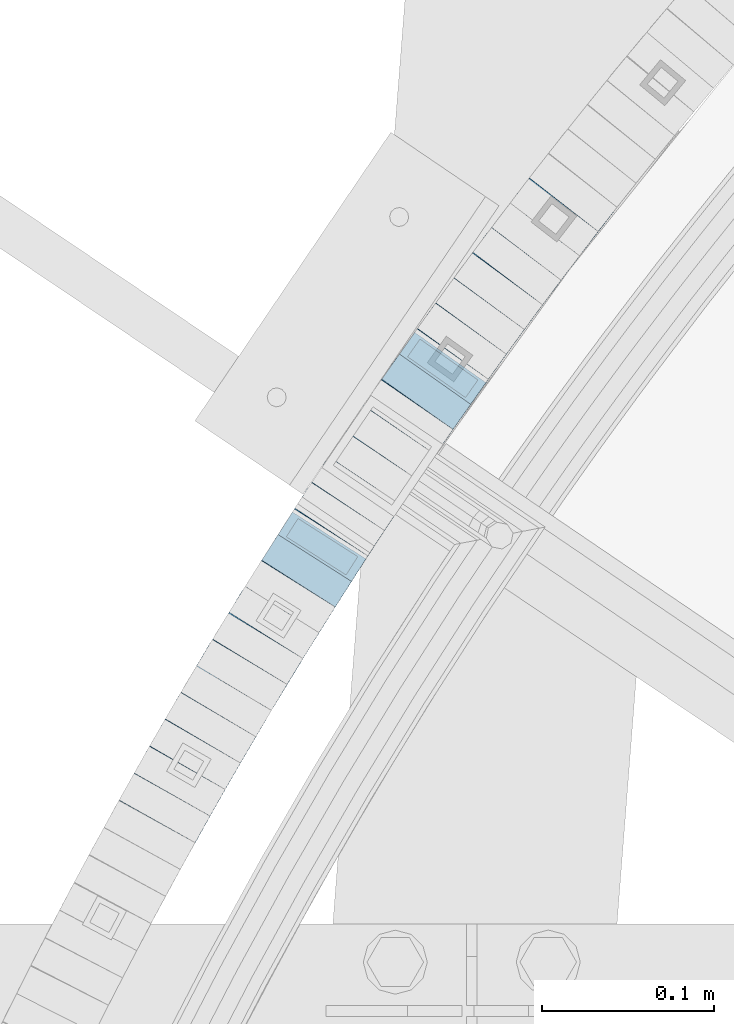
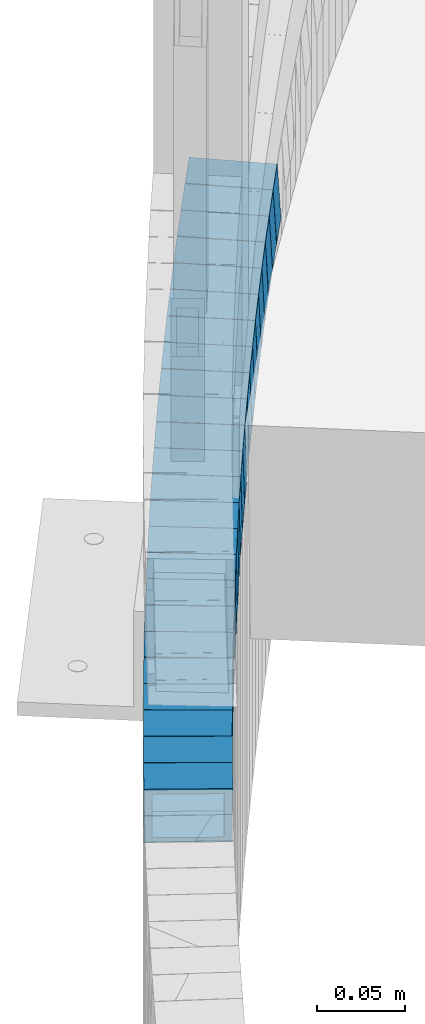
# One storey, part 738 of 975: 24 beams.
"""IFC2X3 building model written with IfcOpenShell, lengths in millimetres."""

from ifc_helpers import new_model, si_unit, frame, origin_with_axes, place, context, subcontext, project, spatial, faceted_brep, material, type_object, element, save


model = new_model("IFC2X3")

# Units and contexts
model_context = context("Model", 3, precision=1e-05, world=origin_with_axes())
body_context = subcontext(model_context, "Body", "Model", "MODEL_VIEW")
ifc_project = project(units=[si_unit("LENGTHUNIT", "METRE", prefix="MILLI"), si_unit("AREAUNIT", "SQUARE_METRE"), si_unit("VOLUMEUNIT", "CUBIC_METRE"), si_unit("MASSUNIT", "GRAM", prefix="KILO"), si_unit("TIMEUNIT", "SECOND"), si_unit("PLANEANGLEUNIT", "RADIAN"), si_unit("SOLIDANGLEUNIT", "STERADIAN"), si_unit("THERMODYNAMICTEMPERATUREUNIT", "DEGREE_CELSIUS"), si_unit("LUMINOUSINTENSITYUNIT", "LUMEN")], contexts=[model_context])

# Site, building, storey
site_placement = place(None, origin_with_axes())
site = spatial("IfcSite", under=ifc_project, at=site_placement, CompositionType="ELEMENT")
building_placement = place(site_placement, origin_with_axes())
building = spatial("IfcBuilding", under=site, at=building_placement, Name="Undefined", CompositionType="ELEMENT")
storey_placement = place(building_placement, origin_with_axes())
storey = spatial("IfcBuildingStorey", under=building, at=storey_placement, Name="Undefined", CompositionType="ELEMENT", Elevation=0.0)

# Beams
ifc_material = material()
beam_type = type_object("IfcBeamType", Name="HSS2X2X.188_TUBES", PredefinedType="NOTDEFINED")
beam_1_placement = place(storey_placement, frame((32470.512431481, 5168.51406782556, 211.007242107061), z_axis=(0.791161585042768, -0.611607183045306, -3.09927372654783e-12), x_axis=(-0.582537973064696, -0.753558295083626, -0.3046299490338)))
element("IfcBeam", 1, at=beam_1_placement, inside=storey, type_object=beam_type, material=ifc_material, Name="WALL", ObjectType="HSS2X2X.188_TUBES", context=body_context, shape_type="Brep", body=[
    faceted_brep([(0.0, 20.6374999999753, -20.6375000000298), (0.0, -20.6375000000153, -20.6375000000153), (18.7112265765609, -20.6375000000062, -20.6374999999862), (18.7112265765645, 20.6374999999898, -20.6374999999789), (0.0, -20.6374999999825, 20.6375000000335), (18.7112265765209, -20.6374999999916, 20.6374999999607), (0.0, 20.6375000000116, 20.6375000000189), (18.7112265765245, 20.6375000000025, 20.6374999999716), (0.0, 25.3999999999724, -25.4000000000342), (0.0, 25.400000000016, 25.4000000000196), (18.7112265765172, 25.4000000000051, 25.3999999999614), (18.7112265765718, 25.3999999999887, -25.3999999999724), (0.0, -25.399999999976, 25.4000000000378), (18.7112265765136, -25.3999999999905, 25.3999999999542), (0.0, -25.400000000016, -25.4000000000196), (18.7112265765682, -25.4000000000069, -25.3999999999796)], [[[0, 1, 2, 3]], [[1, 4, 5, 2]], [[4, 6, 7, 5]], [[6, 0, 3, 7]], [[8, 9, 10, 11]], [[9, 12, 13, 10]], [[12, 14, 15, 13]], [[14, 8, 11, 15]], [[13, 15, 11, 10], [5, 7, 3, 2]], [[14, 12, 9, 8], [6, 4, 1, 0]]]),
])
beam_2_placement = place(storey_placement, frame((32459.4205086382, 5154.30692939824, 205.334225868715), z_axis=(0.797986598681653, -0.602675193055502, -7.64323999646878e-11), x_axis=(-0.573390259939947, -0.759211177920499, -0.307931805967765)))
element("IfcBeam", 2, at=beam_2_placement, inside=storey, type_object=beam_type, material=ifc_material, Name="WALL", ObjectType="HSS2X2X.188_TUBES", context=body_context, shape_type="Brep", body=[
    faceted_brep([(0.0, 20.6374999999753, -20.6375000000298), (0.0, -20.6375000000153, -20.6375000000153), (18.8433011969464, -20.6374999999898, -20.6375000000226), (18.8433011969719, 20.6375000000007, -20.6374999999862), (0.0, -20.6374999999825, 20.6375000000335), (18.8433011969828, -20.6375000000044, 20.6375000000189), (0.0, 20.6375000000116, 20.6375000000189), (18.8433011970155, 20.6374999999862, 20.6375000000517), (0.0, 25.3999999999724, -25.4000000000342), (0.0, 25.400000000016, 25.4000000000196), (18.8433011970228, 25.3999999999833, 25.4000000000597), (18.8433011969719, 25.4000000000015, -25.3999999999869), (0.0, -25.399999999976, 25.4000000000378), (18.8433011969864, -25.4000000000051, 25.4000000000196), (0.0, -25.400000000016, -25.4000000000196), (18.8433011969391, -25.3999999999869, -25.4000000000269)], [[[0, 1, 2, 3]], [[1, 4, 5, 2]], [[4, 6, 7, 5]], [[6, 0, 3, 7]], [[8, 9, 10, 11]], [[9, 12, 13, 10]], [[12, 14, 15, 13]], [[14, 8, 11, 15]], [[13, 15, 11, 10], [5, 7, 3, 2]], [[14, 12, 9, 8], [6, 4, 1, 0]]]),
])
beam_3_placement = place(storey_placement, frame((32448.5467627088, 5139.90928432507, 199.494963266846), z_axis=(0.797986598681653, -0.602675193055502, -7.64323999646878e-11), x_axis=(-0.574321858048529, -0.760444683064125, -0.303114314025563)))
element("IfcBeam", 3, at=beam_3_placement, inside=storey, type_object=beam_type, material=ifc_material, Name="WALL", ObjectType="HSS2X2X.188_TUBES", context=body_context, shape_type="Brep", body=[
    faceted_brep([(0.0, 20.6374999999753, -20.6375000000298), (0.0, -20.6375000000153, -20.6375000000153), (18.8047866246379, -20.6374999999916, -20.6375000000298), (18.8047866247143, 20.6374999999844, -20.6374999999643), (0.0, -20.6374999999825, 20.6375000000335), (18.8047866247107, -20.6375000000189, 20.6375000000407), (0.0, 20.6375000000116, 20.6375000000189), (18.8047866247907, 20.6374999999589, 20.6375000001026), (0.0, 25.3999999999724, -25.4000000000342), (0.0, 25.400000000016, 25.4000000000196), (18.8047866248016, 25.3999999999542, 25.4000000001142), (18.8047866247143, 25.3999999999851, -25.3999999999651), (0.0, -25.399999999976, 25.4000000000378), (18.8047866247107, -25.4000000000196, 25.4000000000415), (0.0, -25.400000000016, -25.4000000000196), (18.8047866246197, -25.3999999999887, -25.4000000000378)], [[[0, 1, 2, 3]], [[1, 4, 5, 2]], [[4, 6, 7, 5]], [[6, 0, 3, 7]], [[8, 9, 10, 11]], [[9, 12, 13, 10]], [[12, 14, 15, 13]], [[14, 8, 11, 15]], [[13, 15, 11, 10], [5, 7, 3, 2]], [[14, 12, 9, 8], [6, 4, 1, 0]]]),
])
beam_4_placement = place(storey_placement, frame((32437.4932962238, 5125.42788626434, 193.799865635897), z_axis=(0.805336883996211, -0.592817428282328, 1.46393176692072e-10), x_axis=(-0.56481344194101, -0.767293732919804, -0.303720435968247)))
element("IfcBeam", 4, at=beam_4_placement, inside=storey, type_object=beam_type, material=ifc_material, Name="WALL", ObjectType="HSS2X2X.188_TUBES", context=body_context, shape_type="Brep", body=[
    faceted_brep([(0.0, 20.6374999999753, -20.6375000000298), (0.0, -20.6375000000153, -20.6375000000153), (18.767258723612, -20.6375000000025, -20.6374999999862), (18.7672587236229, 20.6374999999953, -20.637499999968), (0.0, -20.6374999999825, 20.6375000000335), (18.767258723612, -20.6375000000135, 20.6375000000153), (0.0, 20.6375000000116, 20.6375000000189), (18.7672587236266, 20.6374999999844, 20.6375000000371), (0.0, 25.3999999999724, -25.4000000000342), (0.0, 25.400000000016, 25.4000000000196), (18.7672587236302, 25.3999999999814, 25.4000000000342), (18.7672587236229, 25.399999999996, -25.3999999999687), (0.0, -25.399999999976, 25.4000000000378), (18.7672587236157, -25.4000000000142, 25.400000000016), (0.0, -25.400000000016, -25.4000000000196), (18.767258723612, -25.4000000000015, -25.3999999999905)], [[[0, 1, 2, 3]], [[1, 4, 5, 2]], [[4, 6, 7, 5]], [[6, 0, 3, 7]], [[8, 9, 10, 11]], [[9, 12, 13, 10]], [[12, 14, 15, 13]], [[14, 8, 11, 15]], [[13, 15, 11, 10], [5, 7, 3, 2]], [[14, 12, 9, 8], [6, 4, 1, 0]]]),
])
beam_5_placement = place(storey_placement, frame((32426.8833960046, 5111.0739182393, 188.146913664702), z_axis=(0.808007530182552, -0.589172157495831, -9.53824894622811e-11), x_axis=(-0.56024905492496, -0.768341560897181, -0.30947090695859)))
element("IfcBeam", 5, at=beam_5_placement, inside=storey, type_object=beam_type, material=ifc_material, Name="WALL", ObjectType="HSS2X2X.188_TUBES", context=body_context, shape_type="Brep", body=[
    faceted_brep([(0.0, 20.6374999999753, -20.6375000000298), (0.0, -20.6375000000153, -20.6375000000153), (18.7416648140024, -20.6375000000153, -20.6374999999825), (18.7416648139188, 20.6375000000189, -20.6375000000298), (0.0, -20.6374999999825, 20.6375000000335), (18.7416648140097, -20.6375000000189, 20.6375000000226), (0.0, 20.6375000000116, 20.6375000000189), (18.741664813926, 20.6375000000153, 20.6374999999753), (0.0, 25.3999999999724, -25.4000000000342), (0.0, 25.400000000016, 25.4000000000196), (18.7416648139224, 25.4000000000196, 25.3999999999687), (18.7416648139042, 25.4000000000233, -25.4000000000378), (0.0, -25.399999999976, 25.4000000000378), (18.7416648140133, -25.4000000000215, 25.4000000000269), (0.0, -25.400000000016, -25.4000000000196), (18.7416648140133, -25.4000000000196, -25.399999999976)], [[[0, 1, 2, 3]], [[1, 4, 5, 2]], [[4, 6, 7, 5]], [[6, 0, 3, 7]], [[8, 9, 10, 11]], [[9, 12, 13, 10]], [[12, 14, 15, 13]], [[14, 8, 11, 15]], [[13, 15, 11, 10], [5, 7, 3, 2]], [[14, 12, 9, 8], [6, 4, 1, 0]]]),
])
beam_6_placement = place(storey_placement, frame((32416.135373959, 5096.41819714573, 182.287120287444), z_axis=(0.811850633169245, -0.583865180861726, 6.69017197196809e-11), x_axis=(-0.556577063147289, -0.773907155204776, -0.302141834079939)))
element("IfcBeam", 6, at=beam_6_placement, inside=storey, type_object=beam_type, material=ifc_material, Name="WALL", ObjectType="HSS2X2X.188_TUBES", context=body_context, shape_type="Brep", body=[
    faceted_brep([(0.0, 20.6374999999753, -20.6375000000298), (0.0, -20.6375000000153, -20.6375000000153), (18.8653120832787, -20.6374999999989, -20.6374999999935), (18.8653120832823, 20.6374999999971, -20.6374999999935), (0.0, -20.6374999999825, 20.6375000000335), (18.8653120833151, -20.6375000000116, 20.6375000000298), (0.0, 20.6375000000116, 20.6375000000189), (18.8653120833151, 20.6374999999844, 20.6375000000298), (0.0, 25.3999999999724, -25.4000000000342), (0.0, 25.400000000016, 25.4000000000196), (18.8653120833187, 25.3999999999814, 25.4000000000378), (18.8653120832823, 25.3999999999942, -25.3999999999905), (0.0, -25.399999999976, 25.4000000000378), (18.8653120833187, -25.4000000000124, 25.4000000000342), (0.0, -25.400000000016, -25.4000000000196), (18.8653120832787, -25.3999999999978, -25.3999999999942)], [[[0, 1, 2, 3]], [[1, 4, 5, 2]], [[4, 6, 7, 5]], [[6, 0, 3, 7]], [[8, 9, 10, 11]], [[9, 12, 13, 10]], [[12, 14, 15, 13]], [[14, 8, 11, 15]], [[13, 15, 11, 10], [5, 7, 3, 2]], [[14, 12, 9, 8], [6, 4, 1, 0]]]),
])
beam_7_placement = place(storey_placement, frame((32405.5414254194, 5081.80782671915, 176.640969983465), z_axis=(0.817122939314865, -0.576463443806662, 1.1020227930203e-10), x_axis=(-0.548299120091753, -0.777200694130077, -0.308750961051682)))
element("IfcBeam", 7, at=beam_7_placement, inside=storey, type_object=beam_type, material=ifc_material, Name="WALL", ObjectType="HSS2X2X.188_TUBES", context=body_context, shape_type="Brep", body=[
    faceted_brep([(0.0, 20.6374999999753, -20.6375000000298), (0.0, -20.6375000000153, -20.6375000000153), (18.7853666454903, -20.6375000000535, -20.6375000000326), (18.785366645363, 20.6374999999862, -20.6375000000044), (0.0, -20.6374999999825, 20.6375000000335), (18.785366645352, -20.6375000000007, 20.6374999999989), (0.0, 20.6375000000116, 20.6375000000189), (18.7853666453102, 20.6375000000025, 20.6374999999753), (0.0, 25.3999999999724, -25.4000000000342), (0.0, 25.400000000016, 25.4000000000196), (18.7853666452065, 25.4000000000451, 25.4000000000351), (18.7853666453739, 25.3999999999833, -25.400000000006), (0.0, -25.399999999976, 25.4000000000378), (18.7853666497213, -25.399999993424, 25.3999999995158), (0.0, -25.400000000016, -25.4000000000196), (18.7853666455194, -25.4000000000633, -25.4000000000406)], [[[0, 1, 2, 3]], [[1, 4, 5, 2]], [[4, 6, 7, 5]], [[6, 0, 3, 7]], [[8, 9, 10, 11]], [[9, 12, 13, 10]], [[12, 14, 15, 13]], [[14, 8, 11, 15]], [[13, 15, 11, 10], [5, 7, 3, 2]], [[14, 12, 9, 8], [6, 4, 1, 0]]]),
])
beam_8_placement = place(storey_placement, frame((32384.6184411076, 5052.29333871853, 165.08824907381), z_axis=(0.823392066898081, -0.567472910515828, 1.08082133465359e-10), x_axis=(-0.540925699845856, -0.784872584776216, -0.302282008913816)))
element("IfcBeam", 8, at=beam_8_placement, inside=storey, type_object=beam_type, material=ifc_material, Name="WALL", ObjectType="HSS2X2X.188_TUBES", context=body_context, shape_type="Brep", body=[
    faceted_brep([(0.0, 20.6374999999753, -20.6375000000298), (0.0, -20.6375000000153, -20.6375000000153), (18.8565638439322, -20.6375000000116, -20.6374999999643), (18.8565638439395, 20.637499999988, -20.6374999999534), (0.0, -20.6374999999825, 20.6375000000335), (18.856563843914, -20.6374999999953, 20.6375000000116), (0.0, 20.6375000000116, 20.6375000000189), (18.8565638439177, 20.6375000000007, 20.6375000000226), (0.0, 25.3999999999724, -25.4000000000342), (0.0, 25.400000000016, 25.4000000000196), (18.8565638439177, 25.4000000000033, 25.4000000000233), (18.8565638439468, 25.3999999999851, -25.3999999999505), (0.0, -25.399999999976, 25.4000000000378), (18.8565638439104, -25.399999999996, 25.4000000000087), (0.0, -25.400000000016, -25.4000000000196), (18.8565638439395, -25.4000000000124, -25.3999999999614)], [[[0, 1, 2, 3]], [[1, 4, 5, 2]], [[4, 6, 7, 5]], [[6, 0, 3, 7]], [[8, 9, 10, 11]], [[9, 12, 13, 10]], [[12, 14, 15, 13]], [[14, 8, 11, 15]], [[13, 15, 11, 10], [5, 7, 3, 2]], [[14, 12, 9, 8], [6, 4, 1, 0]]]),
])
beam_9_placement = place(storey_placement, frame((32395.1707377768, 5067.10762870152, 170.801508715522), z_axis=(0.817122939314865, -0.576463443806662, 1.1020227930203e-10), x_axis=(-0.549194709889728, -0.778470170843574, -0.303923285938926)))
element("IfcBeam", 9, at=beam_9_placement, inside=storey, type_object=beam_type, material=ifc_material, Name="WALL", ObjectType="HSS2X2X.188_TUBES", context=body_context, shape_type="Brep", body=[
    faceted_brep([(0.0, 20.6374999999753, -20.6375000000298), (0.0, -20.6375000000153, -20.6375000000153), (18.7547327359644, -20.6374999999844, -20.6375000000553), (18.7547327359898, 20.6375000000171, -20.6375000000335), (0.0, -20.6374999999825, 20.6375000000335), (18.7547327360044, -20.6374999999953, 20.6374999999898), (0.0, 20.6375000000116, 20.6375000000189), (18.7547327360262, 20.6375000000062, 20.6375000000116), (0.0, 25.3999999999724, -25.4000000000342), (0.0, 25.400000000016, 25.4000000000196), (18.7547327360371, 25.4000000000033, 25.4000000000124), (18.7547327359898, 25.4000000000178, -25.4000000000342), (0.0, -25.399999999976, 25.4000000000378), (18.7547327360044, -25.399999999996, 25.3999999999869), (0.0, -25.400000000016, -25.4000000000196), (18.7547327359498, -25.3999999999814, -25.4000000000597)], [[[0, 1, 2, 3]], [[1, 4, 5, 2]], [[4, 6, 7, 5]], [[6, 0, 3, 7]], [[8, 9, 10, 11]], [[9, 12, 13, 10]], [[12, 14, 15, 13]], [[14, 8, 11, 15]], [[13, 15, 11, 10], [5, 7, 3, 2]], [[14, 12, 9, 8], [6, 4, 1, 0]]]),
])
beam_10_placement = place(storey_placement, frame((32364.1511830103, 5022.6167131502, 153.637752726729), z_axis=(0.83029632017577, -0.557322187520447, 1.60824868089548e-10), x_axis=(-0.530163642253865, -0.789835630378182, -0.30836048614765)))
element("IfcBeam", 10, at=beam_10_placement, inside=storey, type_object=beam_type, material=ifc_material, Name="WALL", ObjectType="HSS2X2X.188_TUBES", context=body_context, shape_type="Brep", body=[
    faceted_brep([(0.0, 20.6374999999753, -20.6375000000298), (0.0, -20.6375000000153, -20.6375000000153), (18.4848586686057, -20.6374999999989, -20.6374999999825), (18.4848586686603, 20.6374999999862, -20.6375000000735), (0.0, -20.6374999999825, 20.6375000000335), (18.4848586686203, -20.6374999999935, 20.6374999999898), (0.0, 20.6375000000116, 20.6375000000189), (18.4848586686712, 20.6374999999898, 20.6374999998989), (0.0, 25.3999999999724, -25.4000000000342), (0.0, 25.400000000016, 25.4000000000196), (18.4848586686821, 25.3999999999878, 25.3999999998778), (18.4848586686676, 25.3999999999833, -25.4000000000815), (0.0, -25.399999999976, 25.4000000000378), (18.4848586686167, -25.3999999999915, 25.3999999999905), (0.0, -25.400000000016, -25.4000000000196), (18.4848586686021, -25.3999999999978, -25.3999999999687)], [[[0, 1, 2, 3]], [[1, 4, 5, 2]], [[4, 6, 7, 5]], [[6, 0, 3, 7]], [[8, 9, 10, 11]], [[9, 12, 13, 10]], [[12, 14, 15, 13]], [[14, 8, 11, 15]], [[13, 15, 11, 10], [5, 7, 3, 2]], [[14, 12, 9, 8], [6, 4, 1, 0]]]),
])
beam_11_placement = place(storey_placement, frame((32374.4047168572, 5037.53629673165, 159.434511288634), z_axis=(0.825991087710894, -0.56368317610354, -8.04351145688995e-11), x_axis=(-0.53628659205303, -0.785845603077769, -0.307966523030481)))
element("IfcBeam", 11, at=beam_11_placement, inside=storey, type_object=beam_type, material=ifc_material, Name="WALL", ObjectType="HSS2X2X.188_TUBES", context=body_context, shape_type="Brep", body=[
    faceted_brep([(0.0, 20.6374999999753, -20.6375000000298), (0.0, -20.6375000000153, -20.6375000000153), (18.8332159191086, -20.6374999999916, -20.6375000000153), (18.8332159190923, 20.6375000000062, -20.6375000000335), (0.0, -20.6374999999825, 20.6375000000335), (18.8332159191377, -20.6375000000062, 20.6375000000335), (0.0, 20.6375000000116, 20.6375000000189), (18.8332159191141, 20.6374999999916, 20.6375000000116), (0.0, 25.3999999999724, -25.4000000000342), (0.0, 25.400000000016, 25.4000000000196), (18.8332159191159, 25.3999999999905, 25.4000000000124), (18.8332159190886, 25.4000000000069, -25.4000000000415), (0.0, -25.399999999976, 25.4000000000378), (18.8332159191395, -25.4000000000069, 25.4000000000378), (0.0, -25.400000000016, -25.4000000000196), (18.8332159191104, -25.3999999999905, -25.400000000016)], [[[0, 1, 2, 3]], [[1, 4, 5, 2]], [[4, 6, 7, 5]], [[6, 0, 3, 7]], [[8, 9, 10, 11]], [[9, 12, 13, 10]], [[12, 14, 15, 13]], [[14, 8, 11, 15]], [[13, 15, 11, 10], [5, 7, 3, 2]], [[14, 12, 9, 8], [6, 4, 1, 0]]]),
])
beam_12_placement = place(storey_placement, frame((32354.1986759092, 5007.83272264112, 147.88723296313), z_axis=(0.832050294337872, -0.554700196225187, 1.688249540166e-14), x_axis=(-0.528772702174652, -0.793159053262076, -0.302155830099841)))
element("IfcBeam", 12, at=beam_12_placement, inside=storey, type_object=beam_type, material=ifc_material, Name="WALL", ObjectType="HSS2X2X.188_TUBES", context=body_context, shape_type="Brep", body=[
    faceted_brep([(0.0, 20.6374999999753, -20.6375000000298), (0.0, -20.6375000000153, -20.6375000000153), (18.5334832127955, -20.637499999998, -20.6375000000044), (18.5334832127846, 20.6375000000071, -20.637499999968), (0.0, -20.6374999999825, 20.6375000000335), (18.533483212821, -20.6375000000035, 20.6374999999389), (0.0, 20.6375000000116, 20.6375000000189), (18.5334832128137, 20.6375000000007, 20.6374999999753), (0.0, 25.3999999999724, -25.4000000000342), (0.0, 25.400000000016, 25.4000000000196), (18.5334832128101, 25.4000000000005, 25.3999999999724), (18.533483212781, 25.400000000006, -25.3999999999614), (0.0, -25.399999999976, 25.4000000000378), (18.5334832128283, -25.4000000000042, 25.3999999999251), (0.0, -25.400000000016, -25.4000000000196), (18.5334832127955, -25.3999999999969, -25.4000000000015)], [[[0, 1, 2, 3]], [[1, 4, 5, 2]], [[4, 6, 7, 5]], [[6, 0, 3, 7]], [[8, 9, 10, 11]], [[9, 12, 13, 10]], [[12, 14, 15, 13]], [[14, 8, 11, 15]], [[13, 15, 11, 10], [5, 7, 3, 2]], [[14, 12, 9, 8], [6, 4, 1, 0]]]),
])
beam_13_placement = place(storey_placement, frame((32344.3006451878, 4993.09429427627, 142.323322220486), z_axis=(0.836371790698747, -0.548162592415217, 1.04352636753902e-10), x_axis=(-0.521761825886772, -0.796090208827333, -0.306602309933495)))
element("IfcBeam", 13, at=beam_13_placement, inside=storey, type_object=beam_type, material=ifc_material, Name="WALL", ObjectType="HSS2X2X.188_TUBES", context=body_context, shape_type="Brep", body=[
    faceted_brep([(0.0, 20.6374999999753, -20.6375000000298), (0.0, -20.6375000000153, -20.6375000000153), (18.5908579683237, -20.6374999999862, -20.6375000000553), (18.5908579683601, 20.6374999999971, -20.6374999999971), (0.0, -20.6374999999825, 20.6375000000335), (18.5908579683455, -20.637500000008, 20.6374999999825), (0.0, 20.6375000000116, 20.6375000000189), (18.5908579683855, 20.6374999999734, 20.637500000048), (0.0, 25.3999999999724, -25.4000000000342), (0.0, 25.400000000016, 25.4000000000196), (18.5908579683928, 25.3999999999705, 25.400000000056), (18.5908579683637, 25.3999999999978, -25.3999999999978), (0.0, -25.399999999976, 25.4000000000378), (18.5908579683455, -25.4000000000106, 25.3999999999833), (0.0, -25.400000000016, -25.4000000000196), (18.5908579683164, -25.3999999999833, -25.4000000000669)], [[[0, 1, 2, 3]], [[1, 4, 5, 2]], [[4, 6, 7, 5]], [[6, 0, 3, 7]], [[8, 9, 10, 11]], [[9, 12, 13, 10]], [[12, 14, 15, 13]], [[14, 8, 11, 15]], [[13, 15, 11, 10], [5, 7, 3, 2]], [[14, 12, 9, 8], [6, 4, 1, 0]]]),
])
beam_14_placement = place(storey_placement, frame((32334.2836351906, 4977.98288126687, 136.586772795974), z_axis=(0.843195132005619, -0.53760763514112, -3.67517998256517e-11), x_axis=(-0.512488812033987, -0.803798241053377, -0.302098668020053)))
element("IfcBeam", 14, at=beam_14_placement, inside=storey, type_object=beam_type, material=ifc_material, Name="WALL", ObjectType="HSS2X2X.188_TUBES", context=body_context, shape_type="Brep", body=[
    faceted_brep([(0.0, 20.6374999999753, -20.6375000000298), (0.0, -20.6375000000153, -20.6375000000153), (18.5369900468904, -20.6375000000025, -20.6375000000262), (18.5369900468904, 20.6374999999971, -20.6375000000262), (0.0, -20.6374999999825, 20.6375000000335), (18.5369900469159, -20.6375000000007, 20.6375000000116), (0.0, 20.6375000000116, 20.6375000000189), (18.5369900469159, 20.6374999999989, 20.6375000000116), (0.0, 25.3999999999724, -25.4000000000342), (0.0, 25.400000000016, 25.4000000000196), (18.5369900469195, 25.3999999999978, 25.4000000000124), (18.5369900468904, 25.3999999999978, -25.4000000000306), (0.0, -25.399999999976, 25.4000000000378), (18.5369900469232, -25.4000000000015, 25.400000000016), (0.0, -25.400000000016, -25.4000000000196), (18.5369900468831, -25.4000000000015, -25.4000000000269)], [[[0, 1, 2, 3]], [[1, 4, 5, 2]], [[4, 6, 7, 5]], [[6, 0, 3, 7]], [[8, 9, 10, 11]], [[9, 12, 13, 10]], [[12, 14, 15, 13]], [[14, 8, 11, 15]], [[13, 15, 11, 10], [5, 7, 3, 2]], [[14, 12, 9, 8], [6, 4, 1, 0]]]),
])
beam_15_placement = place(storey_placement, frame((32324.8504128937, 4963.18761682215, 131.026487667814), z_axis=(0.843195132005619, -0.53760763514112, -3.67517998256517e-11), x_axis=(-0.511648220254278, -0.802479840398789, -0.306988932152552)))
element("IfcBeam", 15, at=beam_15_placement, inside=storey, type_object=beam_type, material=ifc_material, Name="WALL", ObjectType="HSS2X2X.188_TUBES", context=body_context, shape_type="Brep", body=[
    faceted_brep([(0.0, 20.6374999999753, -20.6375000000298), (0.0, -20.6375000000153, -20.6375000000153), (18.5674446276062, -20.6375000000025, -20.6374999999898), (18.5674446275571, 20.6375000000053, -20.6374999999025), (0.0, -20.6374999999825, 20.6375000000335), (18.5674446276444, -20.6375000000135, 20.6374999999098), (0.0, 20.6375000000116, 20.6375000000189), (18.5674446275953, 20.6374999999953, 20.6374999999971), (0.0, 25.3999999999724, -25.4000000000342), (0.0, 25.400000000016, 25.4000000000196), (18.5674446275916, 25.399999999996, 25.4000000000087), (18.567444627548, 25.4000000000069, -25.399999999885), (0.0, -25.399999999976, 25.4000000000378), (18.5674446276571, -25.400000000016, 25.399999999885), (0.0, -25.400000000016, -25.4000000000196), (18.5674446276043, -25.4000000000015, -25.3999999999942)], [[[0, 1, 2, 3]], [[1, 4, 5, 2]], [[4, 6, 7, 5]], [[6, 0, 3, 7]], [[8, 9, 10, 11]], [[9, 12, 13, 10]], [[12, 14, 15, 13]], [[14, 8, 11, 15]], [[13, 15, 11, 10], [5, 7, 3, 2]], [[14, 12, 9, 8], [6, 4, 1, 0]]]),
])
for number, where, z_axis, x_axis, name in (
    (16, (32315.1865469166, 4948.14212456982, 125.322488108995), (0.847362966907137, -0.531014126285107, -9.36697688302955e-11), (-0.505456707110561, -0.806579851176397, -0.306500344067034), "WALL"),
    (17, (32305.7865469166, 4933.14212456982, 119.622488109071), (0.847362966907137, -0.531014126285107, -9.36697688302955e-11), (-0.505456707110561, -0.806579851176397, -0.306500344067034), "WALL"),
):
    element("IfcBeam", number, at=place(storey_placement, frame(where, z_axis=z_axis, x_axis=x_axis)), inside=storey, type_object=beam_type, material=ifc_material, Name=name, ObjectType="HSS2X2X.188_TUBES", context=body_context, shape_type="Brep", body=[
        faceted_brep([(0.0, 20.6374999999753, -20.6375000000298), (0.0, -20.6375000000153, -20.6375000000153), (18.5970427756438, -20.6375000000062, -20.6375000000044), (18.5970427756838, 20.6374999999935, -20.6374999999498), (0.0, -20.6374999999825, 20.6375000000335), (18.5970427756511, -20.6374999999935, 20.6374999999935), (0.0, 20.6375000000116, 20.6375000000189), (18.5970427756911, 20.6375000000044, 20.637500000048), (0.0, 25.3999999999724, -25.4000000000342), (0.0, 25.400000000016, 25.4000000000196), (18.5970427756947, 25.4000000000069, 25.4000000000487), (18.5970427756874, 25.3999999999905, -25.3999999999432), (0.0, -25.399999999976, 25.4000000000378), (18.5970427756474, -25.3999999999924, 25.3999999999869), (0.0, -25.400000000016, -25.4000000000196), (18.5970427756401, -25.4000000000069, -25.4000000000051)], [[[0, 1, 2, 3]], [[1, 4, 5, 2]], [[4, 6, 7, 5]], [[6, 0, 3, 7]], [[8, 9, 10, 11]], [[9, 12, 13, 10]], [[12, 14, 15, 13]], [[14, 8, 11, 15]], [[13, 15, 11, 10], [5, 7, 3, 2]], [[14, 12, 9, 8], [6, 4, 1, 0]]]),
    ])
beam_16_placement = place(storey_placement, frame((32296.0635586701, 4917.84767534108, 113.914137668214), z_axis=(0.855500079109598, -0.517802679254822, 1.05275375972269e-10), x_axis=(-0.493051351760085, -0.814606580603593, -0.305477467851354)))
element("IfcBeam", 18, at=beam_16_placement, inside=storey, type_object=beam_type, material=ifc_material, Name="WALL", ObjectType="HSS2X2X.188_TUBES", context=body_context, shape_type="Brep", body=[
    faceted_brep([(0.0, 20.6374999999753, -20.6375000000298), (0.0, -20.6375000000153, -20.6375000000153), (18.6593140280638, -20.6374999999971, -20.6375000000226), (18.6593140281293, 20.6374999999862, -20.6374999999862), (0.0, -20.6374999999825, 20.6375000000335), (18.6593140281693, -20.6375000000226, 20.6375000000407), (0.0, 20.6375000000116, 20.6375000000189), (18.6593140282275, 20.6374999999625, 20.6375000000771), (0.0, 25.3999999999724, -25.4000000000342), (0.0, 25.400000000016, 25.4000000000196), (18.6593140282457, 25.3999999999578, 25.4000000000888), (18.6593140281184, 25.3999999999887, -25.3999999999905), (0.0, -25.399999999976, 25.4000000000378), (18.6593140281766, -25.4000000000233, 25.4000000000487), (0.0, -25.400000000016, -25.4000000000196), (18.6593140280456, -25.3999999999905, -25.4000000000342)], [[[0, 1, 2, 3]], [[1, 4, 5, 2]], [[4, 6, 7, 5]], [[6, 0, 3, 7]], [[8, 9, 10, 11]], [[9, 12, 13, 10]], [[12, 14, 15, 13]], [[14, 8, 11, 15]], [[13, 15, 11, 10], [5, 7, 3, 2]], [[14, 12, 9, 8], [6, 4, 1, 0]]]),
])
beam_17_placement = place(storey_placement, frame((32286.8746714615, 4902.62245351586, 108.185394433509), z_axis=(0.853980061205121, -0.520305732299864, 2.23161137569151e-10), x_axis=(-0.496023546782428, -0.814125604642948, -0.301927376867576)))
element("IfcBeam", 19, at=beam_17_placement, inside=storey, type_object=beam_type, material=ifc_material, Name="WALL", ObjectType="HSS2X2X.188_TUBES", context=body_context, shape_type="Brep", body=[
    faceted_brep([(0.0, 20.6374999999753, -20.6375000000298), (0.0, -20.6375000000153, -20.6375000000153), (18.5475065709179, -20.6374999999916, -20.6375000000335), (18.5475065709143, 20.6375000000062, -20.6375000000298), (0.0, -20.6374999999825, 20.6375000000335), (18.5475065709543, -20.6375000000007, 20.6375000000189), (0.0, 20.6375000000116, 20.6375000000189), (18.5475065709579, 20.6374999999971, 20.6375000000262), (0.0, 25.3999999999724, -25.4000000000342), (0.0, 25.400000000016, 25.4000000000196), (18.5475065709616, 25.399999999996, 25.4000000000342), (18.5475065709106, 25.4000000000087, -25.4000000000342), (0.0, -25.399999999976, 25.4000000000378), (18.5475065709616, -25.4000000000015, 25.4000000000269), (0.0, -25.400000000016, -25.4000000000196), (18.5475065709106, -25.3999999999905, -25.4000000000415)], [[[0, 1, 2, 3]], [[1, 4, 5, 2]], [[4, 6, 7, 5]], [[6, 0, 3, 7]], [[8, 9, 10, 11]], [[9, 12, 13, 10]], [[12, 14, 15, 13]], [[14, 8, 11, 15]], [[13, 15, 11, 10], [5, 7, 3, 2]], [[14, 12, 9, 8], [6, 4, 1, 0]]]),
])
for number, where, z_axis, x_axis, name in (
    (20, (32277.419805907, 4887.32939553113, 102.616250429638), (0.861934215234034, -0.507020126433744, 1.94830604982598e-10), (-0.482742038327502, -0.8206614655567, -0.305736624207403), "WALL"),
    (21, (32268.419805907, 4872.02939553113, 96.9162504297156), (0.861934215234034, -0.507020126433744, 1.94830604982598e-10), (-0.482742038327502, -0.8206614655567, -0.305736624207403), "WALL"),
):
    element("IfcBeam", number, at=place(storey_placement, frame(where, z_axis=z_axis, x_axis=x_axis)), inside=storey, type_object=beam_type, material=ifc_material, Name=name, ObjectType="HSS2X2X.188_TUBES", context=body_context, shape_type="Brep", body=[
        faceted_brep([(0.0, 20.6374999999753, -20.6375000000298), (0.0, -20.6375000000153, -20.6375000000153), (18.6434975259435, -20.6375000000025, -20.6374999999898), (18.6434975259363, 20.6375000000025, -20.6374999999935), (0.0, -20.6374999999825, 20.6375000000335), (18.6434975259399, -20.6375000000062, 20.6375000000116), (0.0, 20.6375000000116, 20.6375000000189), (18.6434975259363, 20.6375000000007, 20.6375000000044), (0.0, 25.3999999999724, -25.4000000000342), (0.0, 25.400000000016, 25.4000000000196), (18.6434975259363, 25.4000000000015, 25.4000000000087), (18.6434975259363, 25.4000000000051, -25.3999999999905), (0.0, -25.399999999976, 25.4000000000378), (18.6434975259472, -25.4000000000069, 25.4000000000124), (0.0, -25.400000000016, -25.4000000000196), (18.6434975259472, -25.4000000000033, -25.3999999999869)], [[[0, 1, 2, 3]], [[1, 4, 5, 2]], [[4, 6, 7, 5]], [[6, 0, 3, 7]], [[8, 9, 10, 11]], [[9, 12, 13, 10]], [[12, 14, 15, 13]], [[14, 8, 11, 15]], [[13, 15, 11, 10], [5, 7, 3, 2]], [[14, 12, 9, 8], [6, 4, 1, 0]]]),
    ])
beam_18_placement = place(storey_placement, frame((32259.2625685976, 4856.57827381987, 91.2116761107207), z_axis=(0.865810948744288, -0.500371263198153, -9.59833528213493e-11), x_axis=(-0.476501660957225, -0.824508490926134, -0.305175220972664)))
element("IfcBeam", 22, at=beam_18_placement, inside=storey, type_object=beam_type, material=ifc_material, Name="WALL", ObjectType="HSS2X2X.188_TUBES", context=body_context, shape_type="Brep", body=[
    faceted_brep([(0.0, 20.6374999999753, -20.6375000000298), (0.0, -20.6375000000153, -20.6375000000153), (18.677794302308, -20.6374999999989, -20.6374999999862), (18.6777943022862, 20.6375000000098, -20.6375000000153), (0.0, -20.6374999999825, 20.6375000000335), (18.6777943022862, -20.6375000000044, 20.6374999999862), (0.0, 20.6375000000116, 20.6375000000189), (18.6777943022644, 20.6375000000044, 20.6374999999571), (0.0, 25.3999999999724, -25.4000000000342), (0.0, 25.400000000016, 25.4000000000196), (18.6777943022607, 25.4000000000033, 25.3999999999505), (18.6777943022898, 25.4000000000124, -25.400000000016), (0.0, -25.399999999976, 25.4000000000378), (18.6777943022862, -25.4000000000069, 25.3999999999905), (0.0, -25.400000000016, -25.4000000000196), (18.6777943023117, -25.3999999999978, -25.3999999999796)], [[[0, 1, 2, 3]], [[1, 4, 5, 2]], [[4, 6, 7, 5]], [[6, 0, 3, 7]], [[8, 9, 10, 11]], [[9, 12, 13, 10]], [[12, 14, 15, 13]], [[14, 8, 11, 15]], [[13, 15, 11, 10], [5, 7, 3, 2]], [[14, 12, 9, 8], [6, 4, 1, 0]]]),
])
beam_19_placement = place(storey_placement, frame((32250.2070228553, 4841.02615218244, 85.5069947645359), z_axis=(0.869620813888916, -0.493720204216092, -7.76339419417127e-11), x_axis=(-0.470258877823184, -0.828296886688579, -0.304599499885483)))
element("IfcBeam", 23, at=beam_19_placement, inside=storey, type_object=beam_type, material=ifc_material, Name="WALL", ObjectType="HSS2X2X.188_TUBES", context=body_context, shape_type="Brep", body=[
    faceted_brep([(0.0, 20.6374999999753, -20.6375000000298), (0.0, -20.6375000000153, -20.6375000000153), (18.7112265765609, -20.6375000000062, -20.6374999999862), (18.7112265765645, 20.6374999999898, -20.6374999999789), (0.0, -20.6374999999825, 20.6375000000335), (18.7112265765209, -20.6374999999916, 20.6374999999607), (0.0, 20.6375000000116, 20.6375000000189), (18.7112265765245, 20.6375000000025, 20.6374999999716), (0.0, 25.3999999999724, -25.4000000000342), (0.0, 25.400000000016, 25.4000000000196), (18.7112265765172, 25.4000000000051, 25.3999999999614), (18.7112265765718, 25.3999999999887, -25.3999999999724), (0.0, -25.399999999976, 25.4000000000378), (18.7112265765136, -25.3999999999905, 25.3999999999542), (0.0, -25.400000000016, -25.4000000000196), (18.7112265765682, -25.4000000000069, -25.3999999999796)], [[[0, 1, 2, 3]], [[1, 4, 5, 2]], [[4, 6, 7, 5]], [[6, 0, 3, 7]], [[8, 9, 10, 11]], [[9, 12, 13, 10]], [[12, 14, 15, 13]], [[14, 8, 11, 15]], [[13, 15, 11, 10], [5, 7, 3, 2]], [[14, 12, 9, 8], [6, 4, 1, 0]]]),
])
beam_20_placement = place(storey_placement, frame((32241.3129274136, 4825.4801889866, 79.8416917865016), z_axis=(0.873363874286145, -0.487068314604733, 1.57350356744245e-10), x_axis=(-0.463257735166816, -0.830669042299017, -0.308838490111168)))
element("IfcBeam", 24, at=beam_20_placement, inside=storey, type_object=beam_type, material=ifc_material, Name="WALL", ObjectType="HSS2X2X.188_TUBES", context=body_context, shape_type="Brep", body=[
    faceted_brep([(0.0, 20.6374999999753, -20.6375000000298), (0.0, -20.6375000000153, -20.6375000000153), (18.7771137292038, -20.637500000008, -20.6374999999862), (18.777113729182, 20.6375000000062, -20.6375000000189), (0.0, -20.6374999999825, 20.6375000000335), (18.7771137291729, -20.6374999999916, 20.6374999999753), (0.0, 20.6375000000116, 20.6375000000189), (18.7771137291529, 20.6375000000207, 20.6374999999389), (0.0, 25.3999999999724, -25.4000000000342), (0.0, 25.400000000016, 25.4000000000196), (18.7771137291475, 25.4000000000251, 25.3999999999287), (18.7771137291857, 25.4000000000051, -25.4000000000196), (0.0, -25.399999999976, 25.4000000000378), (18.7771137291711, -25.3999999999905, 25.3999999999724), (0.0, -25.400000000016, -25.4000000000196), (18.7771137292129, -25.4000000000124, -25.3999999999724)], [[[0, 1, 2, 3]], [[1, 4, 5, 2]], [[4, 6, 7, 5]], [[6, 0, 3, 7]], [[8, 9, 10, 11]], [[9, 12, 13, 10]], [[12, 14, 15, 13]], [[14, 8, 11, 15]], [[13, 15, 11, 10], [5, 7, 3, 2]], [[14, 12, 9, 8], [6, 4, 1, 0]]]),
])

save(model, "model.ifc")
